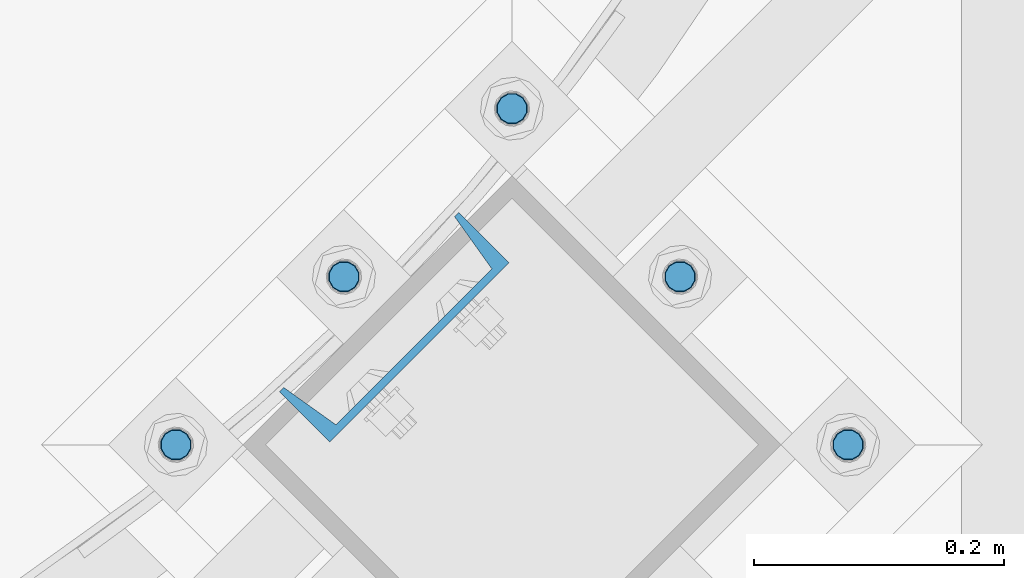
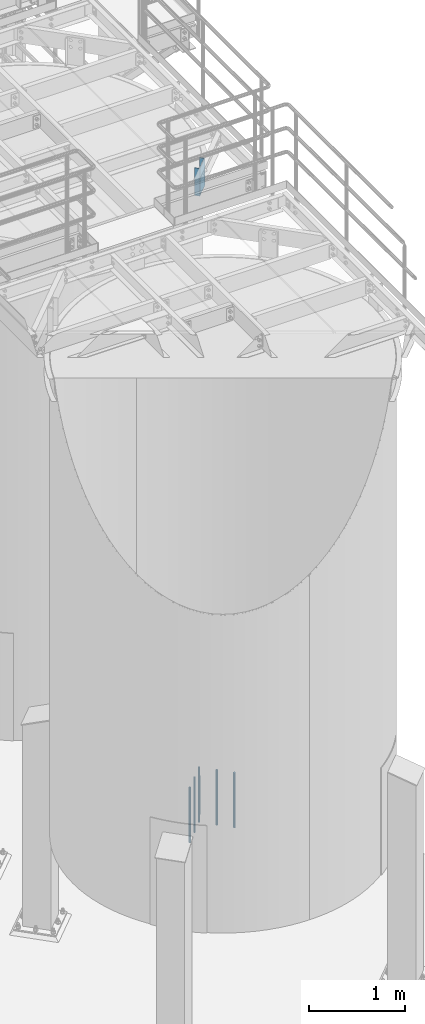
# One storey, part 796 of 1876: 6 columns, 2 elements without a shape of their own.
"""IFC2X3 building model written with IfcOpenShell, lengths in millimetres."""

from ifc_helpers import new_model, si_unit, frame, origin_with_axes, place, context, subcontext, project, spatial, faceted_brep, material, type_object, element, aggregate, save


model = new_model("IFC2X3")

# Units and contexts
model_context = context("Model", 3, precision=1e-05, world=origin_with_axes())
body_context = subcontext(model_context, "Body", "Model", "MODEL_VIEW")
ifc_project = project(units=[si_unit("LENGTHUNIT", "METRE", prefix="MILLI"), si_unit("AREAUNIT", "SQUARE_METRE"), si_unit("VOLUMEUNIT", "CUBIC_METRE"), si_unit("MASSUNIT", "GRAM", prefix="KILO"), si_unit("TIMEUNIT", "SECOND"), si_unit("PLANEANGLEUNIT", "RADIAN"), si_unit("SOLIDANGLEUNIT", "STERADIAN"), si_unit("THERMODYNAMICTEMPERATUREUNIT", "DEGREE_CELSIUS"), si_unit("LUMINOUSINTENSITYUNIT", "LUMEN")], contexts=[model_context])

# Site, building, storey
site_placement = place(None, origin_with_axes())
site = spatial("IfcSite", under=ifc_project, at=site_placement, CompositionType="ELEMENT")
building_placement = place(site_placement, origin_with_axes())
building = spatial("IfcBuilding", under=site, at=building_placement, Name="Undefined", CompositionType="ELEMENT")
storey_placement = place(building_placement, origin_with_axes())
storey = spatial("IfcBuildingStorey", under=building, at=storey_placement, Name="Undefined", CompositionType="ELEMENT", Elevation=0.0)

# Assembly, column
assembly_1_placement = place(storey_placement, origin_with_axes())
assembly_1 = element("IfcElementAssembly", 1, at=assembly_1_placement, inside=storey, Name="BEAM", AssemblyPlace="NOTDEFINED", PredefinedType="RIGID_FRAME")
ifc_material_1 = material(Name="STEEL/A36")
column_type_1 = type_object("IfcColumnType", Name="C8X11.5", PredefinedType="NOTDEFINED")
column_1_placement = place(assembly_1_placement, frame((6485.96521257532, -10842.029092196, 7620.0), z_axis=(0.707106781186548, 0.707106781186547, 0.0), x_axis=(0.0, 0.0, 1.0)))
column_1 = element("IfcColumn", 2, at=column_1_placement, type_object=column_type_1, material=ifc_material_1, Name="BEAM", ObjectType="C8X11.5", context=body_context, shape_type="Brep", body=[
    faceted_brep([(0.0, 28.5749999999998, -101.6), (0.0, 28.5749999999998, 101.6), (352.425, 28.5749999999998, 101.6), (352.425, 28.5749999999998, -101.6), (0.0, -28.5749999999998, 101.6), (352.425, -28.5749999999998, 101.6), (0.0, -28.5749999999998, 96.8355950000005), (352.425, -28.5749999999998, 96.8355950000005), (0.0, 22.2250000000004, 88.3723150000005), (352.425, 22.2250000000004, 88.3723150000005), (0.0, 22.2250000000004, -88.3723150000005), (352.425, 22.2250000000004, -88.3723150000005), (0.0, -28.5749999999998, -96.8355950000005), (352.425, -28.5749999999998, -96.8355950000005), (0.0, -28.5749999999998, -101.6), (352.425, -28.5749999999998, -101.6)], [[[0, 1, 2, 3]], [[1, 4, 5, 2]], [[4, 6, 7, 5]], [[6, 8, 9, 7]], [[8, 10, 11, 9]], [[10, 12, 13, 11]], [[12, 14, 15, 13]], [[14, 0, 3, 15]], [[5, 7, 9, 11, 13, 15, 3, 2]], [[14, 12, 10, 8, 6, 4, 1, 0]]]),
])
aggregate(assembly_1, [column_1])

# Assembly, columns
assembly_2_placement = place(storey_placement, origin_with_axes())
assembly_2 = element("IfcElementAssembly", 3, at=assembly_2_placement, inside=storey, Name="TEMPLATE", AssemblyPlace="NOTDEFINED", PredefinedType="RIGID_FRAME")
ifc_material_2 = material(Name="STEEL/F1554-GR.105")
column_type_2 = type_object("IfcColumnType", PredefinedType="NOTDEFINED")
column_2_placement = place(assembly_2_placement, frame((6849.68588892531, -10936.2323904103, 7.105427357601e-15), z_axis=(0.707106781186548, 0.707106781186547, 0.0), x_axis=(0.0, 0.0, -1.0)))
column_2 = element("IfcColumn", 4, at=column_2_placement, type_object=column_type_2, material=ifc_material_2, Name="ANCHOR_BOLTS", context=body_context, shape_type="Brep", body=[
    faceted_brep([(-114.3, -10.3923048454853, 6.0000000001337), (-114.3, -6.00000000006912, 10.3923048455481), (-114.3, -6.54836185276508e-11, 12.0000000001355), (-114.3, 5.99999999993634, 10.3923048455481), (-114.3, 10.3923048453526, 6.00000000013279), (-114.3, 11.9999999999418, 1.29148247651756e-10), (-114.3, 10.3923048453507, -5.99999999987358), (-114.3, 5.99999999993815, -10.392304845288), (-114.3, -6.54836185276508e-11, -11.9999999998781), (-114.3, -6.00000000006912, -10.3923048452889), (-114.3, -10.3923048454853, -5.99999999987358), (-114.3, -12.0000000000728, 1.28238752949983e-10), (0.0, 11.9999999999418, 1.29148247651756e-10), (0.0, 10.3923048453507, -5.99999999987358), (0.0, 5.99999999993815, -10.392304845288), (0.0, -6.54836185276508e-11, -11.9999999998781), (0.0, -6.00000000006912, -10.3923048452889), (0.0, -10.3923048454853, -5.99999999987358), (0.0, -12.0000000000728, 1.28238752949983e-10), (0.0, -10.3923048454853, 6.0000000001337), (0.0, -6.00000000006912, 10.3923048455481), (0.0, -6.54836185276508e-11, 12.0000000001355), (0.0, 5.99999999993634, 10.3923048455481), (0.0, 10.3923048453526, 6.00000000013279), (0.0, -10.998522628066, 6.35000000000218), (0.0, -6.35000000000218, 10.9985226280642), (0.0, 0.0, 12.7000000000035), (0.0, 6.34999999999854, 10.9985226280651), (0.0, 10.9985226280623, 6.35000000000218), (0.0, 12.6999999999998, 0.0), (0.0, 10.9985226280623, -6.35000000000127), (0.0, 6.34999999999854, -10.9985226280633), (0.0, 0.0, -12.7000000000016), (0.0, -6.35000000000218, -10.9985226280642), (0.0, -10.998522628066, -6.35000000000127), (0.0, -12.6999999999998, 0.0), (488.95, -12.7000000000044, 9.09494701772928e-13), (488.95, -10.998522628066, 6.35000000000218), (488.95, -6.35000000000218, 10.9985226280642), (488.95, 0.0, 12.7000000000035), (488.95, 6.34999999999854, 10.9985226280651), (488.95, 10.9985226280623, 6.35000000000218), (488.95, 12.7000000000007, 9.09494701772928e-13), (488.95, 10.9985226280623, -6.35000000000127), (488.95, 6.34999999999854, -10.9985226280633), (488.95, 0.0, -12.7000000000016), (488.95, -6.35000000000218, -10.9985226280642), (488.95, -10.998522628066, -6.35000000000127), (488.95, -6.00000000006912, 10.3923048455481), (488.95, -6.54836185276508e-11, 12.0000000001355), (488.95, 5.99999999993634, 10.3923048455481), (488.95, 10.3923048453526, 6.00000000013279), (488.95, 11.9999999999418, 1.29148247651756e-10), (488.95, 10.3923048453507, -5.99999999987358), (488.95, 5.99999999993815, -10.392304845288), (488.95, -6.54836185276508e-11, -11.9999999998781), (488.95, -6.00000000006912, -10.3923048452889), (488.95, -10.3923048454853, -5.99999999987358), (488.95, -12.0000000000728, 1.28238752949983e-10), (488.95, -10.3923048454853, 6.0000000001337), (590.55, -6.00000000006912, -10.3923048452889), (590.55, -6.54836185276508e-11, -11.9999999998781), (590.55, 5.99999999993815, -10.392304845288), (590.55, 10.3923048453507, -5.99999999987358), (590.55, 11.9999999999418, 1.29148247651756e-10), (590.55, 10.3923048453526, 6.00000000013279), (590.55, 5.99999999993634, 10.3923048455481), (590.55, -6.54836185276508e-11, 12.0000000001355), (590.55, -6.00000000006912, 10.3923048455481), (590.55, -10.3923048454853, 6.0000000001337), (590.55, -12.0000000000728, 1.28238752949983e-10), (590.55, -10.3923048454853, -5.99999999987358)], [[[0, 1, 2, 3, 4, 5, 6, 7, 8, 9, 10, 11]], [[6, 5, 12, 13]], [[7, 6, 13, 14]], [[8, 7, 14, 15]], [[9, 8, 15, 16]], [[10, 9, 16, 17]], [[11, 10, 17, 18]], [[0, 11, 18, 19]], [[1, 0, 19, 20]], [[2, 1, 20, 21]], [[3, 2, 21, 22]], [[4, 3, 22, 23]], [[5, 4, 23, 12]], [[24, 25, 26, 27, 28, 29, 30, 31, 32, 33, 34, 35], [22, 21, 20, 19, 18, 17, 16, 15, 14, 13, 12, 23]], [[24, 35, 36, 37]], [[25, 24, 37, 38]], [[26, 25, 38, 39]], [[27, 26, 39, 40]], [[28, 27, 40, 41]], [[29, 28, 41, 42]], [[30, 29, 42, 43]], [[31, 30, 43, 44]], [[32, 31, 44, 45]], [[33, 32, 45, 46]], [[34, 33, 46, 47]], [[35, 34, 47, 36]], [[46, 45, 44, 43, 42, 41, 40, 39, 38, 37, 36, 47], [48, 49, 50, 51, 52, 53, 54, 55, 56, 57, 58, 59]], [[60, 61, 62, 63, 64, 65, 66, 67, 68, 69, 70, 71]], [[68, 67, 49, 48]], [[69, 68, 48, 59]], [[70, 69, 59, 58]], [[71, 70, 58, 57]], [[60, 71, 57, 56]], [[61, 60, 56, 55]], [[62, 61, 55, 54]], [[63, 62, 54, 53]], [[64, 63, 53, 52]], [[65, 64, 52, 51]], [[66, 65, 51, 50]], [[67, 66, 50, 49]]]),
])
column_3_placement = place(assembly_2_placement, frame((6714.98204710916, -10801.5285485942, 7.105427357601e-15), z_axis=(0.707106781186548, 0.707106781186547, 0.0), x_axis=(0.0, 0.0, -1.0)))
column_3 = element("IfcColumn", 5, at=column_3_placement, type_object=column_type_2, material=ifc_material_2, Name="ANCHOR_BOLTS", context=body_context, shape_type="Brep", body=[
    faceted_brep([(-114.3, -10.3923048454853, 6.0000000001337), (-114.3, -6.00000000006912, 10.3923048455481), (-114.3, -6.54836185276508e-11, 12.0000000001355), (-114.3, 5.99999999993634, 10.3923048455481), (-114.3, 10.3923048453526, 6.00000000013279), (-114.3, 11.9999999999418, 1.29148247651756e-10), (-114.3, 10.3923048453507, -5.99999999987358), (-114.3, 5.99999999993815, -10.392304845288), (-114.3, -6.54836185276508e-11, -11.9999999998781), (-114.3, -6.00000000006912, -10.3923048452889), (-114.3, -10.3923048454853, -5.99999999987358), (-114.3, -12.0000000000728, 1.28238752949983e-10), (0.0, 11.9999999999418, 1.29148247651756e-10), (0.0, 10.3923048453507, -5.99999999987358), (0.0, 5.99999999993815, -10.392304845288), (0.0, -6.54836185276508e-11, -11.9999999998781), (0.0, -6.00000000006912, -10.3923048452889), (0.0, -10.3923048454853, -5.99999999987358), (0.0, -12.0000000000728, 1.28238752949983e-10), (0.0, -10.3923048454853, 6.0000000001337), (0.0, -6.00000000006912, 10.3923048455481), (0.0, -6.54836185276508e-11, 12.0000000001355), (0.0, 5.99999999993634, 10.3923048455481), (0.0, 10.3923048453526, 6.00000000013279), (0.0, -10.998522628066, 6.35000000000218), (0.0, -6.35000000000218, 10.9985226280642), (0.0, 0.0, 12.7000000000035), (0.0, 6.34999999999854, 10.9985226280651), (0.0, 10.9985226280623, 6.35000000000218), (0.0, 12.6999999999998, 0.0), (0.0, 10.9985226280623, -6.35000000000127), (0.0, 6.34999999999854, -10.9985226280633), (0.0, 0.0, -12.7000000000016), (0.0, -6.35000000000218, -10.9985226280642), (0.0, -10.998522628066, -6.35000000000127), (0.0, -12.6999999999998, 0.0), (488.95, -12.7000000000044, 9.09494701772928e-13), (488.95, -10.998522628066, 6.35000000000218), (488.95, -6.35000000000218, 10.9985226280642), (488.95, 0.0, 12.7000000000035), (488.95, 6.34999999999854, 10.9985226280651), (488.95, 10.9985226280623, 6.35000000000218), (488.95, 12.7000000000007, 9.09494701772928e-13), (488.95, 10.9985226280623, -6.35000000000127), (488.95, 6.34999999999854, -10.9985226280633), (488.95, 0.0, -12.7000000000016), (488.95, -6.35000000000218, -10.9985226280642), (488.95, -10.998522628066, -6.35000000000127), (488.95, -6.00000000006912, 10.3923048455481), (488.95, -6.54836185276508e-11, 12.0000000001355), (488.95, 5.99999999993634, 10.3923048455481), (488.95, 10.3923048453526, 6.00000000013279), (488.95, 11.9999999999418, 1.29148247651756e-10), (488.95, 10.3923048453507, -5.99999999987358), (488.95, 5.99999999993815, -10.392304845288), (488.95, -6.54836185276508e-11, -11.9999999998781), (488.95, -6.00000000006912, -10.3923048452889), (488.95, -10.3923048454853, -5.99999999987358), (488.95, -12.0000000000728, 1.28238752949983e-10), (488.95, -10.3923048454853, 6.0000000001337), (590.55, -6.00000000006912, -10.3923048452889), (590.55, -6.54836185276508e-11, -11.9999999998781), (590.55, 5.99999999993815, -10.392304845288), (590.55, 10.3923048453507, -5.99999999987358), (590.55, 11.9999999999418, 1.29148247651756e-10), (590.55, 10.3923048453526, 6.00000000013279), (590.55, 5.99999999993634, 10.3923048455481), (590.55, -6.54836185276508e-11, 12.0000000001355), (590.55, -6.00000000006912, 10.3923048455481), (590.55, -10.3923048454853, 6.0000000001337), (590.55, -12.0000000000728, 1.28238752949983e-10), (590.55, -10.3923048454853, -5.99999999987358)], [[[0, 1, 2, 3, 4, 5, 6, 7, 8, 9, 10, 11]], [[6, 5, 12, 13]], [[7, 6, 13, 14]], [[8, 7, 14, 15]], [[9, 8, 15, 16]], [[10, 9, 16, 17]], [[11, 10, 17, 18]], [[0, 11, 18, 19]], [[1, 0, 19, 20]], [[2, 1, 20, 21]], [[3, 2, 21, 22]], [[4, 3, 22, 23]], [[5, 4, 23, 12]], [[24, 25, 26, 27, 28, 29, 30, 31, 32, 33, 34, 35], [22, 21, 20, 19, 18, 17, 16, 15, 14, 13, 12, 23]], [[24, 35, 36, 37]], [[25, 24, 37, 38]], [[26, 25, 38, 39]], [[27, 26, 39, 40]], [[28, 27, 40, 41]], [[29, 28, 41, 42]], [[30, 29, 42, 43]], [[31, 30, 43, 44]], [[32, 31, 44, 45]], [[33, 32, 45, 46]], [[34, 33, 46, 47]], [[35, 34, 47, 36]], [[46, 45, 44, 43, 42, 41, 40, 39, 38, 37, 36, 47], [48, 49, 50, 51, 52, 53, 54, 55, 56, 57, 58, 59]], [[60, 61, 62, 63, 64, 65, 66, 67, 68, 69, 70, 71]], [[68, 67, 49, 48]], [[69, 68, 48, 59]], [[70, 69, 59, 58]], [[71, 70, 58, 57]], [[60, 71, 57, 56]], [[61, 60, 56, 55]], [[62, 61, 55, 54]], [[63, 62, 54, 53]], [[64, 63, 53, 52]], [[65, 64, 52, 51]], [[66, 65, 51, 50]], [[67, 66, 50, 49]]]),
])
column_4_placement = place(assembly_2_placement, frame((6580.27820529301, -10666.824706778, 7.105427357601e-15), z_axis=(-0.707106781186547, -0.707106781186548, 0.0), x_axis=(0.0, 0.0, -1.0)))
column_4 = element("IfcColumn", 6, at=column_4_placement, type_object=column_type_2, material=ifc_material_2, Name="ANCHOR_BOLTS", context=body_context, shape_type="Brep", body=[
    faceted_brep([(-114.3, -10.3923048454853, 6.0000000001337), (-114.3, -6.00000000006912, 10.3923048455481), (-114.3, -6.54836185276508e-11, 12.0000000001355), (-114.3, 5.99999999993634, 10.3923048455481), (-114.3, 10.3923048453526, 6.00000000013279), (-114.3, 11.9999999999418, 1.29148247651756e-10), (-114.3, 10.3923048453507, -5.99999999987358), (-114.3, 5.99999999993815, -10.392304845288), (-114.3, -6.54836185276508e-11, -11.9999999998781), (-114.3, -6.00000000006912, -10.3923048452889), (-114.3, -10.3923048454853, -5.99999999987358), (-114.3, -12.0000000000728, 1.28238752949983e-10), (0.0, 11.9999999999418, 1.29148247651756e-10), (0.0, 10.3923048453507, -5.99999999987358), (0.0, 5.99999999993815, -10.392304845288), (0.0, -6.54836185276508e-11, -11.9999999998781), (0.0, -6.00000000006912, -10.3923048452889), (0.0, -10.3923048454853, -5.99999999987358), (0.0, -12.0000000000728, 1.28238752949983e-10), (0.0, -10.3923048454853, 6.0000000001337), (0.0, -6.00000000006912, 10.3923048455481), (0.0, -6.54836185276508e-11, 12.0000000001355), (0.0, 5.99999999993634, 10.3923048455481), (0.0, 10.3923048453526, 6.00000000013279), (0.0, -10.998522628066, 6.35000000000218), (0.0, -6.35000000000218, 10.9985226280642), (0.0, 0.0, 12.7000000000035), (0.0, 6.34999999999854, 10.9985226280651), (0.0, 10.9985226280623, 6.35000000000218), (0.0, 12.6999999999998, 0.0), (0.0, 10.9985226280623, -6.35000000000127), (0.0, 6.34999999999854, -10.9985226280633), (0.0, 0.0, -12.7000000000016), (0.0, -6.35000000000218, -10.9985226280642), (0.0, -10.998522628066, -6.35000000000127), (0.0, -12.6999999999998, 0.0), (488.95, -12.7000000000044, 9.09494701772928e-13), (488.95, -10.998522628066, 6.35000000000218), (488.95, -6.35000000000218, 10.9985226280642), (488.95, 0.0, 12.7000000000035), (488.95, 6.34999999999854, 10.9985226280651), (488.95, 10.9985226280623, 6.35000000000218), (488.95, 12.7000000000007, 9.09494701772928e-13), (488.95, 10.9985226280623, -6.35000000000127), (488.95, 6.34999999999854, -10.9985226280633), (488.95, 0.0, -12.7000000000016), (488.95, -6.35000000000218, -10.9985226280642), (488.95, -10.998522628066, -6.35000000000127), (488.95, -6.00000000006912, 10.3923048455481), (488.95, -6.54836185276508e-11, 12.0000000001355), (488.95, 5.99999999993634, 10.3923048455481), (488.95, 10.3923048453526, 6.00000000013279), (488.95, 11.9999999999418, 1.29148247651756e-10), (488.95, 10.3923048453507, -5.99999999987358), (488.95, 5.99999999993815, -10.392304845288), (488.95, -6.54836185276508e-11, -11.9999999998781), (488.95, -6.00000000006912, -10.3923048452889), (488.95, -10.3923048454853, -5.99999999987358), (488.95, -12.0000000000728, 1.28238752949983e-10), (488.95, -10.3923048454853, 6.0000000001337), (590.55, -6.00000000006912, -10.3923048452889), (590.55, -6.54836185276508e-11, -11.9999999998781), (590.55, 5.99999999993815, -10.392304845288), (590.55, 10.3923048453507, -5.99999999987358), (590.55, 11.9999999999418, 1.29148247651756e-10), (590.55, 10.3923048453526, 6.00000000013279), (590.55, 5.99999999993634, 10.3923048455481), (590.55, -6.54836185276508e-11, 12.0000000001355), (590.55, -6.00000000006912, 10.3923048455481), (590.55, -10.3923048454853, 6.0000000001337), (590.55, -12.0000000000728, 1.28238752949983e-10), (590.55, -10.3923048454853, -5.99999999987358)], [[[0, 1, 2, 3, 4, 5, 6, 7, 8, 9, 10, 11]], [[6, 5, 12, 13]], [[7, 6, 13, 14]], [[8, 7, 14, 15]], [[9, 8, 15, 16]], [[10, 9, 16, 17]], [[11, 10, 17, 18]], [[0, 11, 18, 19]], [[1, 0, 19, 20]], [[2, 1, 20, 21]], [[3, 2, 21, 22]], [[4, 3, 22, 23]], [[5, 4, 23, 12]], [[24, 25, 26, 27, 28, 29, 30, 31, 32, 33, 34, 35], [22, 21, 20, 19, 18, 17, 16, 15, 14, 13, 12, 23]], [[24, 35, 36, 37]], [[25, 24, 37, 38]], [[26, 25, 38, 39]], [[27, 26, 39, 40]], [[28, 27, 40, 41]], [[29, 28, 41, 42]], [[30, 29, 42, 43]], [[31, 30, 43, 44]], [[32, 31, 44, 45]], [[33, 32, 45, 46]], [[34, 33, 46, 47]], [[35, 34, 47, 36]], [[46, 45, 44, 43, 42, 41, 40, 39, 38, 37, 36, 47], [48, 49, 50, 51, 52, 53, 54, 55, 56, 57, 58, 59]], [[60, 61, 62, 63, 64, 65, 66, 67, 68, 69, 70, 71]], [[68, 67, 49, 48]], [[69, 68, 48, 59]], [[70, 69, 59, 58]], [[71, 70, 58, 57]], [[60, 71, 57, 56]], [[61, 60, 56, 55]], [[62, 61, 55, 54]], [[63, 62, 54, 53]], [[64, 63, 53, 52]], [[65, 64, 52, 51]], [[66, 65, 51, 50]], [[67, 66, 50, 49]]]),
])
column_5_placement = place(assembly_2_placement, frame((6445.57436347686, -10801.5285485942, 7.105427357601e-15), z_axis=(-0.707106781186547, -0.707106781186548, 0.0), x_axis=(0.0, 0.0, -1.0)))
column_5 = element("IfcColumn", 7, at=column_5_placement, type_object=column_type_2, material=ifc_material_2, Name="ANCHOR_BOLTS", context=body_context, shape_type="Brep", body=[
    faceted_brep([(-114.3, -10.3923048454853, 6.0000000001337), (-114.3, -6.00000000006912, 10.3923048455481), (-114.3, -6.54836185276508e-11, 12.0000000001355), (-114.3, 5.99999999993634, 10.3923048455481), (-114.3, 10.3923048453526, 6.00000000013279), (-114.3, 11.9999999999418, 1.29148247651756e-10), (-114.3, 10.3923048453507, -5.99999999987358), (-114.3, 5.99999999993815, -10.392304845288), (-114.3, -6.54836185276508e-11, -11.9999999998781), (-114.3, -6.00000000006912, -10.3923048452889), (-114.3, -10.3923048454853, -5.99999999987358), (-114.3, -12.0000000000728, 1.28238752949983e-10), (0.0, 11.9999999999418, 1.29148247651756e-10), (0.0, 10.3923048453507, -5.99999999987358), (0.0, 5.99999999993815, -10.392304845288), (0.0, -6.54836185276508e-11, -11.9999999998781), (0.0, -6.00000000006912, -10.3923048452889), (0.0, -10.3923048454853, -5.99999999987358), (0.0, -12.0000000000728, 1.28238752949983e-10), (0.0, -10.3923048454853, 6.0000000001337), (0.0, -6.00000000006912, 10.3923048455481), (0.0, -6.54836185276508e-11, 12.0000000001355), (0.0, 5.99999999993634, 10.3923048455481), (0.0, 10.3923048453526, 6.00000000013279), (0.0, -10.998522628066, 6.35000000000218), (0.0, -6.35000000000218, 10.9985226280642), (0.0, 0.0, 12.7000000000035), (0.0, 6.34999999999854, 10.9985226280651), (0.0, 10.9985226280623, 6.35000000000218), (0.0, 12.6999999999998, 0.0), (0.0, 10.9985226280623, -6.35000000000127), (0.0, 6.34999999999854, -10.9985226280633), (0.0, 0.0, -12.7000000000016), (0.0, -6.35000000000218, -10.9985226280642), (0.0, -10.998522628066, -6.35000000000127), (0.0, -12.6999999999998, 0.0), (488.95, -12.7000000000044, 9.09494701772928e-13), (488.95, -10.998522628066, 6.35000000000218), (488.95, -6.35000000000218, 10.9985226280642), (488.95, 0.0, 12.7000000000035), (488.95, 6.34999999999854, 10.9985226280651), (488.95, 10.9985226280623, 6.35000000000218), (488.95, 12.7000000000007, 9.09494701772928e-13), (488.95, 10.9985226280623, -6.35000000000127), (488.95, 6.34999999999854, -10.9985226280633), (488.95, 0.0, -12.7000000000016), (488.95, -6.35000000000218, -10.9985226280642), (488.95, -10.998522628066, -6.35000000000127), (488.95, -6.00000000006912, 10.3923048455481), (488.95, -6.54836185276508e-11, 12.0000000001355), (488.95, 5.99999999993634, 10.3923048455481), (488.95, 10.3923048453526, 6.00000000013279), (488.95, 11.9999999999418, 1.29148247651756e-10), (488.95, 10.3923048453507, -5.99999999987358), (488.95, 5.99999999993815, -10.392304845288), (488.95, -6.54836185276508e-11, -11.9999999998781), (488.95, -6.00000000006912, -10.3923048452889), (488.95, -10.3923048454853, -5.99999999987358), (488.95, -12.0000000000728, 1.28238752949983e-10), (488.95, -10.3923048454853, 6.0000000001337), (590.55, -6.00000000006912, -10.3923048452889), (590.55, -6.54836185276508e-11, -11.9999999998781), (590.55, 5.99999999993815, -10.392304845288), (590.55, 10.3923048453507, -5.99999999987358), (590.55, 11.9999999999418, 1.29148247651756e-10), (590.55, 10.3923048453526, 6.00000000013279), (590.55, 5.99999999993634, 10.3923048455481), (590.55, -6.54836185276508e-11, 12.0000000001355), (590.55, -6.00000000006912, 10.3923048455481), (590.55, -10.3923048454853, 6.0000000001337), (590.55, -12.0000000000728, 1.28238752949983e-10), (590.55, -10.3923048454853, -5.99999999987358)], [[[0, 1, 2, 3, 4, 5, 6, 7, 8, 9, 10, 11]], [[6, 5, 12, 13]], [[7, 6, 13, 14]], [[8, 7, 14, 15]], [[9, 8, 15, 16]], [[10, 9, 16, 17]], [[11, 10, 17, 18]], [[0, 11, 18, 19]], [[1, 0, 19, 20]], [[2, 1, 20, 21]], [[3, 2, 21, 22]], [[4, 3, 22, 23]], [[5, 4, 23, 12]], [[24, 25, 26, 27, 28, 29, 30, 31, 32, 33, 34, 35], [22, 21, 20, 19, 18, 17, 16, 15, 14, 13, 12, 23]], [[24, 35, 36, 37]], [[25, 24, 37, 38]], [[26, 25, 38, 39]], [[27, 26, 39, 40]], [[28, 27, 40, 41]], [[29, 28, 41, 42]], [[30, 29, 42, 43]], [[31, 30, 43, 44]], [[32, 31, 44, 45]], [[33, 32, 45, 46]], [[34, 33, 46, 47]], [[35, 34, 47, 36]], [[46, 45, 44, 43, 42, 41, 40, 39, 38, 37, 36, 47], [48, 49, 50, 51, 52, 53, 54, 55, 56, 57, 58, 59]], [[60, 61, 62, 63, 64, 65, 66, 67, 68, 69, 70, 71]], [[68, 67, 49, 48]], [[69, 68, 48, 59]], [[70, 69, 59, 58]], [[71, 70, 58, 57]], [[60, 71, 57, 56]], [[61, 60, 56, 55]], [[62, 61, 55, 54]], [[63, 62, 54, 53]], [[64, 63, 53, 52]], [[65, 64, 52, 51]], [[66, 65, 51, 50]], [[67, 66, 50, 49]]]),
])
column_6_placement = place(assembly_2_placement, frame((6310.87052166071, -10936.2323904103, 7.105427357601e-15), z_axis=(-0.707106781186547, -0.707106781186548, 0.0), x_axis=(0.0, 0.0, -1.0)))
column_6 = element("IfcColumn", 8, at=column_6_placement, type_object=column_type_2, material=ifc_material_2, Name="ANCHOR_BOLTS", context=body_context, shape_type="Brep", body=[
    faceted_brep([(-114.3, -10.3923048454853, 6.0000000001337), (-114.3, -6.00000000006912, 10.3923048455481), (-114.3, -6.54836185276508e-11, 12.0000000001355), (-114.3, 5.99999999993634, 10.3923048455481), (-114.3, 10.3923048453526, 6.00000000013279), (-114.3, 11.9999999999418, 1.29148247651756e-10), (-114.3, 10.3923048453507, -5.99999999987358), (-114.3, 5.99999999993815, -10.392304845288), (-114.3, -6.54836185276508e-11, -11.9999999998781), (-114.3, -6.00000000006912, -10.3923048452889), (-114.3, -10.3923048454853, -5.99999999987358), (-114.3, -12.0000000000728, 1.28238752949983e-10), (0.0, 11.9999999999418, 1.29148247651756e-10), (0.0, 10.3923048453507, -5.99999999987358), (0.0, 5.99999999993815, -10.392304845288), (0.0, -6.54836185276508e-11, -11.9999999998781), (0.0, -6.00000000006912, -10.3923048452889), (0.0, -10.3923048454853, -5.99999999987358), (0.0, -12.0000000000728, 1.28238752949983e-10), (0.0, -10.3923048454853, 6.0000000001337), (0.0, -6.00000000006912, 10.3923048455481), (0.0, -6.54836185276508e-11, 12.0000000001355), (0.0, 5.99999999993634, 10.3923048455481), (0.0, 10.3923048453526, 6.00000000013279), (0.0, -10.998522628066, 6.35000000000218), (0.0, -6.35000000000218, 10.9985226280642), (0.0, 0.0, 12.7000000000035), (0.0, 6.34999999999854, 10.9985226280651), (0.0, 10.9985226280623, 6.35000000000218), (0.0, 12.6999999999998, 0.0), (0.0, 10.9985226280623, -6.35000000000127), (0.0, 6.34999999999854, -10.9985226280633), (0.0, 0.0, -12.7000000000016), (0.0, -6.35000000000218, -10.9985226280642), (0.0, -10.998522628066, -6.35000000000127), (0.0, -12.6999999999998, 0.0), (488.95, -12.7000000000044, 9.09494701772928e-13), (488.95, -10.998522628066, 6.35000000000218), (488.95, -6.35000000000218, 10.9985226280642), (488.95, 0.0, 12.7000000000035), (488.95, 6.34999999999854, 10.9985226280651), (488.95, 10.9985226280623, 6.35000000000218), (488.95, 12.7000000000007, 9.09494701772928e-13), (488.95, 10.9985226280623, -6.35000000000127), (488.95, 6.34999999999854, -10.9985226280633), (488.95, 0.0, -12.7000000000016), (488.95, -6.35000000000218, -10.9985226280642), (488.95, -10.998522628066, -6.35000000000127), (488.95, -6.00000000006912, 10.3923048455481), (488.95, -6.54836185276508e-11, 12.0000000001355), (488.95, 5.99999999993634, 10.3923048455481), (488.95, 10.3923048453526, 6.00000000013279), (488.95, 11.9999999999418, 1.29148247651756e-10), (488.95, 10.3923048453507, -5.99999999987358), (488.95, 5.99999999993815, -10.392304845288), (488.95, -6.54836185276508e-11, -11.9999999998781), (488.95, -6.00000000006912, -10.3923048452889), (488.95, -10.3923048454853, -5.99999999987358), (488.95, -12.0000000000728, 1.28238752949983e-10), (488.95, -10.3923048454853, 6.0000000001337), (590.55, -6.00000000006912, -10.3923048452889), (590.55, -6.54836185276508e-11, -11.9999999998781), (590.55, 5.99999999993815, -10.392304845288), (590.55, 10.3923048453507, -5.99999999987358), (590.55, 11.9999999999418, 1.29148247651756e-10), (590.55, 10.3923048453526, 6.00000000013279), (590.55, 5.99999999993634, 10.3923048455481), (590.55, -6.54836185276508e-11, 12.0000000001355), (590.55, -6.00000000006912, 10.3923048455481), (590.55, -10.3923048454853, 6.0000000001337), (590.55, -12.0000000000728, 1.28238752949983e-10), (590.55, -10.3923048454853, -5.99999999987358)], [[[0, 1, 2, 3, 4, 5, 6, 7, 8, 9, 10, 11]], [[6, 5, 12, 13]], [[7, 6, 13, 14]], [[8, 7, 14, 15]], [[9, 8, 15, 16]], [[10, 9, 16, 17]], [[11, 10, 17, 18]], [[0, 11, 18, 19]], [[1, 0, 19, 20]], [[2, 1, 20, 21]], [[3, 2, 21, 22]], [[4, 3, 22, 23]], [[5, 4, 23, 12]], [[24, 25, 26, 27, 28, 29, 30, 31, 32, 33, 34, 35], [22, 21, 20, 19, 18, 17, 16, 15, 14, 13, 12, 23]], [[24, 35, 36, 37]], [[25, 24, 37, 38]], [[26, 25, 38, 39]], [[27, 26, 39, 40]], [[28, 27, 40, 41]], [[29, 28, 41, 42]], [[30, 29, 42, 43]], [[31, 30, 43, 44]], [[32, 31, 44, 45]], [[33, 32, 45, 46]], [[34, 33, 46, 47]], [[35, 34, 47, 36]], [[46, 45, 44, 43, 42, 41, 40, 39, 38, 37, 36, 47], [48, 49, 50, 51, 52, 53, 54, 55, 56, 57, 58, 59]], [[60, 61, 62, 63, 64, 65, 66, 67, 68, 69, 70, 71]], [[68, 67, 49, 48]], [[69, 68, 48, 59]], [[70, 69, 59, 58]], [[71, 70, 58, 57]], [[60, 71, 57, 56]], [[61, 60, 56, 55]], [[62, 61, 55, 54]], [[63, 62, 54, 53]], [[64, 63, 53, 52]], [[65, 64, 52, 51]], [[66, 65, 51, 50]], [[67, 66, 50, 49]]]),
])
aggregate(assembly_2, [column_2, column_3, column_4, column_5, column_6])

save(model, "model.ifc")
